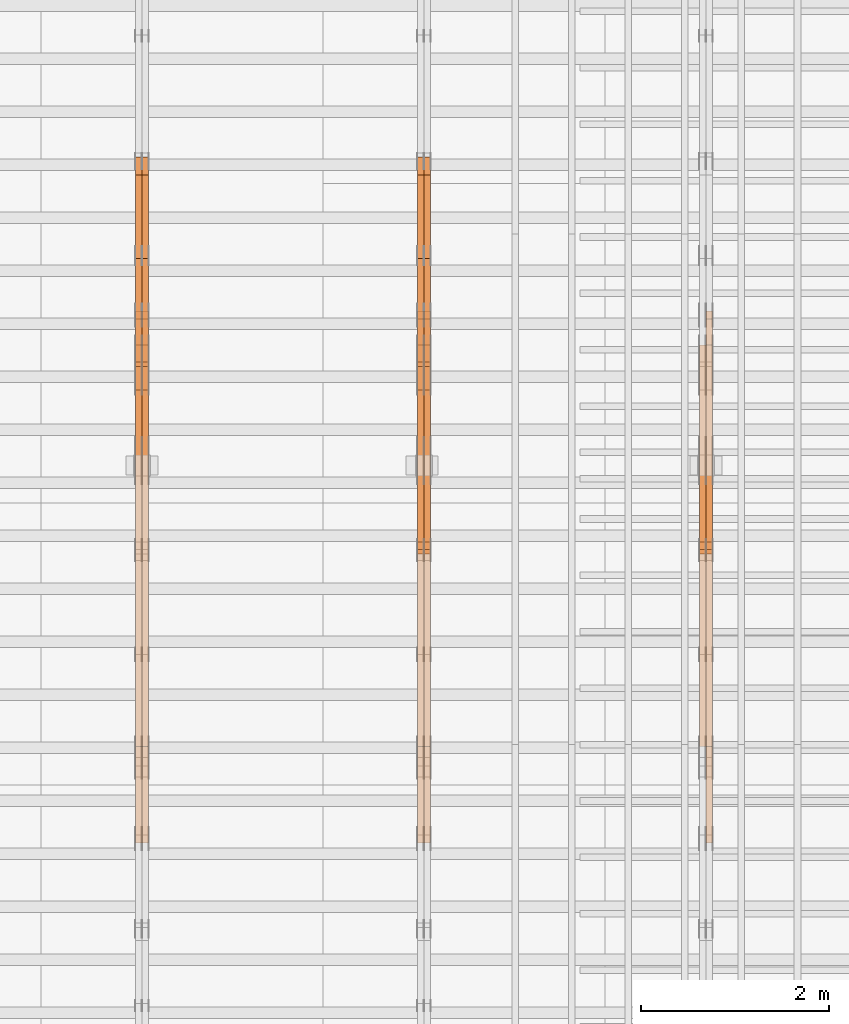
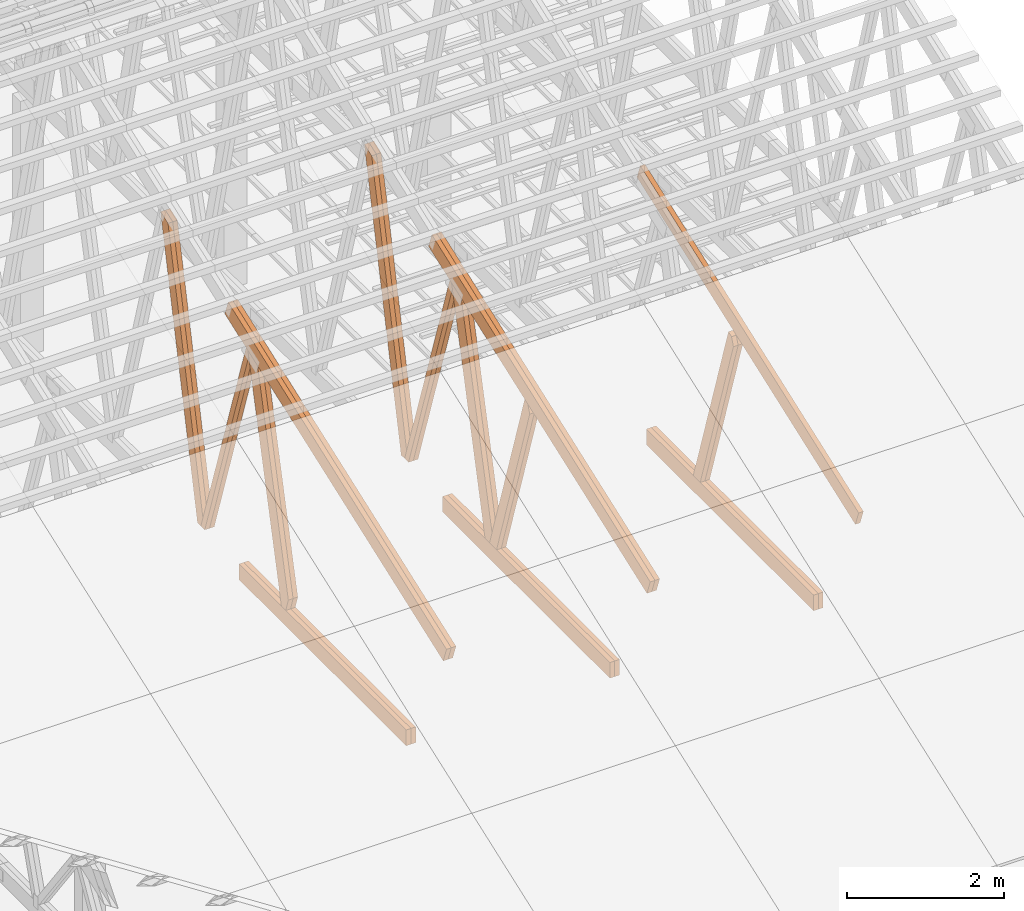
# One storey, part 51 of 189: 27 proxies.
"""IFC2X3 building model written with IfcOpenShell, lengths in millimetres."""

import ifcopenshell
import ifcopenshell.guid

model = None  # the IFC model being written
_history = None  # IfcOwnerHistory: only IFC2X3 demands one
_inside = {}  # id of a spatial element -> (the spatial element, [elements in it])
_under = {}  # id of a project, library or spatial element -> (it, [spatial elements below it])
_declared = {}  # id of a project -> (the project, [libraries it declares])
_typed = {}  # id of a type object -> (the type object, [elements of that type])
_made_of = {}  # id of a material, layer set ... -> (it, [elements and type objects made of it])


def new_model(schema):
    """Start an empty IFC model of exactly this schema.

    Asked for "IFC4X3", IfcOpenShell would pick the latest addendum, in which some entities
    have other attributes; the version numbers below select the first issue.
    IFC2X3 requires an IfcOwnerHistory on every rooted entity: one is made here for all.
    """
    global model, _history
    if schema == "IFC4X3":
        model = ifcopenshell.file(schema_version=(4, 3, 0, 0))
    else:
        model = ifcopenshell.file(schema=schema)
    _inside.clear()
    _under.clear()
    _declared.clear()
    _typed.clear()
    _made_of.clear()
    _history = None
    if model.schema == "IFC2X3":
        org = make("IfcOrganization", Name="unknown")
        user = make(
            "IfcPersonAndOrganization",
            ThePerson=make("IfcPerson", FamilyName="unknown"),
            TheOrganization=org,
        )
        app = make(
            "IfcApplication",
            ApplicationDeveloper=org,
            Version="unknown",
            ApplicationFullName="unknown",
            ApplicationIdentifier="unknown",
        )
        _history = make(
            "IfcOwnerHistory",
            OwningUser=user,
            OwningApplication=app,
            ChangeAction="ADDED",
            CreationDate=0,
        )
    return model


def make(cls, **values):
    """One entity of the class cls with the attributes given. An attribute that is None is left unset."""
    return model.create_entity(
        cls, **{name: value for name, value in values.items() if value is not None}
    )


def entity(cls, *values):
    """Any entity or typed value of the class cls, its attributes in the order of the schema. None: left unset."""
    e = model.create_entity(cls)
    for i, value in enumerate(values):
        if value is not None:
            e[i] = value
    return e


def rooted(cls, **values):
    """An entity with a GlobalId (a new one), such as an element, a storey or a relation."""
    return make(cls, GlobalId=ifcopenshell.guid.new(), OwnerHistory=_history, **values)


def si_unit(unit_type, name, prefix=None):
    """IfcSIUnit, for example si_unit("LENGTHUNIT", "METRE", prefix="MILLI")."""
    return make("IfcSIUnit", UnitType=unit_type, Prefix=prefix, Name=name)


def converted_unit(unit_type, name, factor, base, dimensions=None, offset=None):
    """IfcConversionBasedUnit, such as the inch: factor (a typed value) times the base unit."""
    return make(
        "IfcConversionBasedUnit"
        if offset is None
        else "IfcConversionBasedUnitWithOffset",
        ConversionOffset=offset,
        Dimensions=None
        if dimensions is None
        else entity("IfcDimensionalExponents", *dimensions),
        UnitType=unit_type,
        Name=name,
        ConversionFactor=make(
            "IfcMeasureWithUnit", ValueComponent=factor, UnitComponent=base
        ),
    )


def derived_unit(unit_type, elements):
    """IfcDerivedUnit: a product of units, each with its exponent."""
    return make(
        "IfcDerivedUnit",
        Elements=[
            make("IfcDerivedUnitElement", Unit=unit, Exponent=power)
            for unit, power in elements
        ],
        UnitType=unit_type,
    )


def assignment(units):
    """IfcUnitAssignment: the units of a project."""
    return None if units is None else make("IfcUnitAssignment", Units=units)


def point(xyz):
    """IfcCartesianPoint."""
    return None if xyz is None else make("IfcCartesianPoint", Coordinates=xyz)


def direction(xyz):
    """IfcDirection."""
    return None if xyz is None else make("IfcDirection", DirectionRatios=xyz)


def frame(location, z_axis=None, x_axis=None):
    """IfcAxis2Placement3D, a coordinate frame: its origin and axes. An axis left out is left unset."""
    return make(
        "IfcAxis2Placement3D",
        Location=point(location),
        Axis=direction(z_axis),
        RefDirection=direction(x_axis),
    )


def frame_2d(location, x_axis=None):
    """IfcAxis2Placement2D, a coordinate frame in the plane: its origin and x axis."""
    return make(
        "IfcAxis2Placement2D", Location=point(location), RefDirection=direction(x_axis)
    )


def origin():
    """The frame at (0, 0, 0) with its axes left unset."""
    return frame((0.0, 0.0, 0.0))


def origin_2d_with_axis():
    """The frame at (0, 0) in the plane with the x axis (1, 0) written out."""
    return frame_2d((0.0, 0.0), x_axis=(1.0, 0.0))


def place(relative_to, where):
    """IfcLocalPlacement: puts the frame where relative to a parent placement (None: the world)."""
    return make(
        "IfcLocalPlacement", PlacementRelTo=relative_to, RelativePlacement=where
    )


def context(
    kind, dimensions, precision=None, world=None, true_north=None, identifier=None
):
    """IfcGeometricRepresentationContext, for example the 3D "Model" context."""
    return make(
        "IfcGeometricRepresentationContext",
        ContextIdentifier=identifier,
        ContextType=kind,
        CoordinateSpaceDimension=dimensions,
        Precision=precision,
        WorldCoordinateSystem=world,
        TrueNorth=true_north,
    )


def subcontext(parent, identifier, kind, view, scale=None):
    """IfcGeometricRepresentationSubContext, for example "Body" below "Model"."""
    return make(
        "IfcGeometricRepresentationSubContext",
        ContextIdentifier=identifier,
        ContextType=kind,
        ParentContext=parent,
        TargetScale=scale,
        TargetView=view,
    )


def project(units=None, contexts=None):
    """IfcProject with its units and contexts."""
    return rooted(
        "IfcProject",
        Name="project",
        RepresentationContexts=contexts,
        UnitsInContext=assignment(units),
    )


def spatial(cls, under=None, at=None, **own):
    """A site, building, storey or space (cls), placed at a placement, below another one or the project."""
    s = rooted(cls, ObjectPlacement=at, **own)
    if under is not None:
        _under.setdefault(under.id(), (under, []))[1].append(s)
    return s


def polyline(points):
    """IfcPolyline through the points."""
    return make("IfcPolyline", Points=[point(p) for p in points])


def profile(cls, at=None, kind="AREA", **sizes):
    """A parametric profile (cls). Its sizes go by their IFC names, for example OverallWidth=200.0."""
    return make(cls, ProfileType=kind, Position=at, **sizes)


def rectangle(**sizes):
    """IfcRectangleProfileDef."""
    return profile("IfcRectangleProfileDef", **sizes)


def outline(outer, holes=None, kind="AREA"):
    """IfcArbitraryClosedProfileDef: a profile drawn as a closed curve; with holes, ...WithVoids."""
    if holes is None:
        return make("IfcArbitraryClosedProfileDef", ProfileType=kind, OuterCurve=outer)
    return make(
        "IfcArbitraryProfileDefWithVoids",
        ProfileType=kind,
        OuterCurve=outer,
        InnerCurves=holes,
    )


def extrude(swept, where, along, depth):
    """IfcExtrudedAreaSolid: the profile swept, set in the frame where, extruded along a direction by depth."""
    return make(
        "IfcExtrudedAreaSolid",
        SweptArea=swept,
        Position=where,
        ExtrudedDirection=direction(along),
        Depth=depth,
    )


def shape(context_of_items, identifier, shape_type, items):
    """IfcShapeRepresentation: the items that make up one representation, for example the "Body"."""
    return make(
        "IfcShapeRepresentation",
        ContextOfItems=context_of_items,
        RepresentationIdentifier=identifier,
        RepresentationType=shape_type,
        Items=items,
    )


def source(mapping_origin, context_of_items, identifier, shape_type, items):
    """IfcRepresentationMap: a shape defined once, which mapped items show again and again."""
    return make(
        "IfcRepresentationMap",
        MappingOrigin=mapping_origin,
        MappedRepresentation=shape(context_of_items, identifier, shape_type, items),
    )


def transform(
    local_origin,
    x_axis=None,
    y_axis=None,
    z_axis=None,
    scale=None,
    scale2=None,
    scale3=None,
    uniform=True,
):
    """IfcCartesianTransformationOperator3D, or its non-uniform kind. x_axis, y_axis, z_axis: its Axis1, 2, 3."""
    if uniform:
        return make(
            "IfcCartesianTransformationOperator3D",
            Axis1=direction(x_axis),
            Axis2=direction(y_axis),
            LocalOrigin=point(local_origin),
            Scale=scale,
            Axis3=direction(z_axis),
        )
    return make(
        "IfcCartesianTransformationOperator3DnonUniform",
        Axis1=direction(x_axis),
        Axis2=direction(y_axis),
        LocalOrigin=point(local_origin),
        Scale=scale,
        Axis3=direction(z_axis),
        Scale2=scale2,
        Scale3=scale3,
    )


def mapped(mapping_source, mapping_target):
    """IfcMappedItem: shows the shape of a source again, moved by a transform."""
    return make(
        "IfcMappedItem", MappingSource=mapping_source, MappingTarget=mapping_target
    )


def material(Name=None, Category=None):
    """IfcMaterial."""
    return make("IfcMaterial", Name=Name, Category=Category)


def made_of(thing, what):
    """Note that an element or type object is made of a material, layer set ...; save() writes the relation."""
    if what is not None:
        _made_of.setdefault(what.id(), (what, []))[1].append(thing)
    return thing


def type_object(cls, material=None, **own):
    """A type object (cls), such as IfcWallType, which elements share."""
    return made_of(rooted(cls, **own), material)


def type_shapes(of_type, sources):
    """Give a type object the sources (RepresentationMaps) that its elements show as mapped items."""
    of_type.RepresentationMaps = sources


def element(
    cls,
    number,
    at=None,
    inside=None,
    cuts=None,
    type_object=None,
    material=None,
    context=None,
    identifier="Body",
    shape_type=None,
    held_by="IfcProductDefinitionShape",
    body=None,
    shapes=None,
    **own,
):
    """One element of the class cls, such as IfcWall. Its Tag is "e" and its number.

    at: its placement. inside: the storey or other place that contains it. cuts: it is an
    opening in that element (IfcRelVoidsElement). A single representation is given by context,
    identifier, shape_type and body (its items); several are given by shapes. held_by: the class
    of the entity that holds the representations. save() writes the other relations.
    """
    e = rooted(cls, Tag="e%d" % number, ObjectPlacement=at, **own)
    if body is not None:
        shapes = [shape(context, identifier, shape_type, body)]
    if shapes is not None:
        e.Representation = make(held_by, Representations=shapes)
    if inside is not None:
        _inside.setdefault(inside.id(), (inside, []))[1].append(e)
    if cuts is not None:
        rooted(
            "IfcRelVoidsElement", RelatingBuildingElement=cuts, RelatedOpeningElement=e
        )
    if type_object is not None:
        _typed.setdefault(type_object.id(), (type_object, []))[1].append(e)
    return made_of(e, material)


def aggregate(whole, parts):
    """IfcRelAggregates: a whole, such as a stair, and the parts it consists of."""
    return rooted("IfcRelAggregates", RelatingObject=whole, RelatedObjects=parts)


def save(model, path):
    """Write the relations noted so far, then the file.

    IfcRelAggregates (storeys below a building ...), IfcRelContainedInSpatialStructure (elements
    in a storey), IfcRelDefinesByType, IfcRelAssociatesMaterial and IfcRelDeclares: one each for
    every whole, place, type object, material and project.
    """
    for whole, parts in _under.values():
        aggregate(whole, parts)
    for where, things in _inside.values():
        rooted(
            "IfcRelContainedInSpatialStructure",
            RelatedElements=things,
            RelatingStructure=where,
        )
    for kind, things in _typed.values():
        rooted("IfcRelDefinesByType", RelatedObjects=things, RelatingType=kind)
    for what, things in _made_of.values():
        rooted("IfcRelAssociatesMaterial", RelatedObjects=things, RelatingMaterial=what)
    for by, libraries in _declared.values():
        rooted("IfcRelDeclares", RelatingContext=by, RelatedDefinitions=libraries)
    model.write(path)


model = new_model("IFC2X3")

# Units and contexts
model_context = context("Model", 3, precision=0.01, world=origin(), true_north=direction((6.12303176911189e-17, 1.0)))
body_context = subcontext(model_context, "Body", "Model", "MODEL_VIEW")
ifc_project = project(units=[si_unit("LENGTHUNIT", "METRE", prefix="MILLI"), si_unit("AREAUNIT", "SQUARE_METRE"), si_unit("VOLUMEUNIT", "CUBIC_METRE"), converted_unit("PLANEANGLEUNIT", "DEGREE", entity("IfcRatioMeasure", 0.0174532925199433), si_unit("PLANEANGLEUNIT", "RADIAN"), dimensions=[0, 0, 0, 0, 0, 0, 0]), si_unit("MASSUNIT", "GRAM", prefix="KILO"), derived_unit("MASSDENSITYUNIT", [(si_unit("MASSUNIT", "GRAM", prefix="KILO"), 1), (si_unit("LENGTHUNIT", "METRE"), -3)]), si_unit("TIMEUNIT", "SECOND"), si_unit("FREQUENCYUNIT", "HERTZ"), si_unit("THERMODYNAMICTEMPERATUREUNIT", "DEGREE_CELSIUS"), derived_unit("THERMALTRANSMITTANCEUNIT", [(si_unit("MASSUNIT", "GRAM", prefix="KILO"), 1), (si_unit("THERMODYNAMICTEMPERATUREUNIT", "KELVIN"), -1), (si_unit("TIMEUNIT", "SECOND"), -3)]), derived_unit("VOLUMETRICFLOWRATEUNIT", [(si_unit("LENGTHUNIT", "METRE"), 3), (si_unit("TIMEUNIT", "SECOND"), -1)]), si_unit("ELECTRICCURRENTUNIT", "AMPERE"), si_unit("ELECTRICVOLTAGEUNIT", "VOLT"), si_unit("POWERUNIT", "WATT"), si_unit("FORCEUNIT", "NEWTON"), si_unit("ILLUMINANCEUNIT", "LUX"), si_unit("LUMINOUSFLUXUNIT", "LUMEN"), si_unit("LUMINOUSINTENSITYUNIT", "CANDELA"), derived_unit("USERDEFINED", [(si_unit("MASSUNIT", "GRAM", prefix="KILO"), -1), (si_unit("LENGTHUNIT", "METRE"), -2), (si_unit("TIMEUNIT", "SECOND"), 3), (si_unit("LUMINOUSFLUXUNIT", "LUMEN"), 1)]), derived_unit("LINEARVELOCITYUNIT", [(si_unit("LENGTHUNIT", "METRE"), 1), (si_unit("TIMEUNIT", "SECOND"), -1)]), si_unit("PRESSUREUNIT", "PASCAL"), derived_unit("USERDEFINED", [(si_unit("LENGTHUNIT", "METRE"), -2), (si_unit("MASSUNIT", "GRAM", prefix="KILO"), 1), (si_unit("TIMEUNIT", "SECOND"), -2)])], contexts=[model_context])

# Site, building, storey
site_placement = place(None, origin())
site = spatial("IfcSite", under=ifc_project, at=site_placement, CompositionType="ELEMENT")
building_placement = place(site_placement, origin())
building = spatial("IfcBuilding", under=site, at=building_placement, CompositionType="ELEMENT")
storey_placement = place(building_placement, origin())
storey = spatial("IfcBuildingStorey", under=building, at=storey_placement, Name="Default", CompositionType="ELEMENT", Elevation=0.0)

# Proxies
ifc_material_1 = material(Name="IfcSurfaceStyle #241004")
building_element_proxy_type_1 = type_object("IfcBuildingElementProxyType", Name="T1-W4 241002", PredefinedType="NOTDEFINED", material=ifc_material_1)
shared_shape_1 = source(origin(), body_context, "Body", "SweptSolid", [
    extrude(outline(polyline([(-1688.09292256655, -85.0003489723785), (1071.44998120742, -85.0003489723785), (1178.19407811536, -0.00016040063201781), (1181.35435681367, 85.0004291726946), (-1742.9054935699, 85.0004291726946), (-1688.09292256655, -85.0003489723785)])), frame((1181.35446122976, 85.0007670757732, 0.0), z_axis=(0.0, 0.0, 1.0), x_axis=(-1.0, 0.0, 0.0)), (0.0, 0.0, 1.0), 69.9999999999998),
])
type_shapes(building_element_proxy_type_1, [shared_shape_1])
proxy_1_placement = place(building_placement, frame((45300.0, 7937.17021143291, 3028.170124945), z_axis=(-1.0, 0.0, 0.0), x_axis=(0.0, 0.306868406216492, -0.951751953644514)))
element("IfcBuildingElementProxy", 1, at=proxy_1_placement, inside=storey, type_object=building_element_proxy_type_1, material=ifc_material_1, Name="T1-W4", context=body_context, shape_type="MappedRepresentation", body=[
    mapped(shared_shape_1, transform((0.0, 0.0, 0.0), scale=1.0)),
])
ifc_material_2 = material(Name="IfcSurfaceStyle #240938")
building_element_proxy_type_2 = type_object("IfcBuildingElementProxyType", Name="T1-W4 240936", PredefinedType="NOTDEFINED", material=ifc_material_2)
shared_shape_2 = source(origin(), body_context, "Body", "SweptSolid", [
    extrude(outline(polyline([(-1688.09292256655, -85.0003489723785), (1071.44998120742, -85.0003489723785), (1178.19407811536, -0.00016040063201781), (1181.35435681367, 85.0004291726946), (-1742.9054935699, 85.0004291726946), (-1688.09292256655, -85.0003489723785)])), frame((1181.35446122976, 85.0007670757732, 0.0), z_axis=(0.0, 0.0, 1.0), x_axis=(-1.0, 0.0, 0.0)), (0.0, 0.0, 1.0), 69.9999999999998),
])
type_shapes(building_element_proxy_type_2, [shared_shape_2])
proxy_2_placement = place(building_placement, frame((45230.0, 7937.17021143291, 3028.170124945), z_axis=(-1.0, 0.0, 0.0), x_axis=(0.0, 0.306868406216492, -0.951751953644514)))
element("IfcBuildingElementProxy", 2, at=proxy_2_placement, inside=storey, type_object=building_element_proxy_type_2, material=ifc_material_2, Name="T1-W4", context=body_context, shape_type="MappedRepresentation", body=[
    mapped(shared_shape_2, transform((0.0, 0.0, 0.0), scale=1.0)),
])
ifc_material_3 = material(Name="IfcSurfaceStyle #237926")
building_element_proxy_type_3 = type_object("IfcBuildingElementProxyType", Name="T1-B6 237924", PredefinedType="NOTDEFINED", material=ifc_material_3)
shared_shape_3 = source(origin(), body_context, "Body", "SweptSolid", [
    extrude(rectangle(XDim=4266.763671875, YDim=245.000000000001, at=origin_2d_with_axis()), frame((2133.3818359375, 122.500000000001, 0.0), z_axis=(0.0, 0.0, 1.0), x_axis=(-1.0, 0.0, 0.0)), (0.0, 0.0, 1.0), 69.9999999999997),
])
type_shapes(building_element_proxy_type_3, [shared_shape_3])
proxy_3_placement = place(building_placement, frame((45300.0, 5762.466796875, 245.0), z_axis=(-1.0, 0.0, 0.0), x_axis=(0.0, 1.0, 0.0)))
element("IfcBuildingElementProxy", 3, at=proxy_3_placement, inside=storey, type_object=building_element_proxy_type_3, material=ifc_material_3, Name="T1-B6", context=body_context, shape_type="MappedRepresentation", body=[
    mapped(shared_shape_3, transform((0.0, 0.0, 0.0), scale=1.0)),
])
ifc_material_4 = material(Name="IfcSurfaceStyle #237869")
building_element_proxy_type_4 = type_object("IfcBuildingElementProxyType", Name="T1-B6 237867", PredefinedType="NOTDEFINED", material=ifc_material_4)
shared_shape_4 = source(origin(), body_context, "Body", "SweptSolid", [
    extrude(rectangle(XDim=4266.763671875, YDim=245.000000000001, at=origin_2d_with_axis()), frame((2133.3818359375, 122.500000000001, 0.0), z_axis=(0.0, 0.0, 1.0), x_axis=(-1.0, 0.0, 0.0)), (0.0, 0.0, 1.0), 69.9999999999997),
])
type_shapes(building_element_proxy_type_4, [shared_shape_4])
proxy_4_placement = place(building_placement, frame((45230.0, 5762.466796875, 245.0), z_axis=(-1.0, 0.0, 0.0), x_axis=(0.0, 1.0, 0.0)))
element("IfcBuildingElementProxy", 4, at=proxy_4_placement, inside=storey, type_object=building_element_proxy_type_4, material=ifc_material_4, Name="T1-B6", context=body_context, shape_type="MappedRepresentation", body=[
    mapped(shared_shape_4, transform((0.0, 0.0, 0.0), scale=1.0)),
])
ifc_material_5 = material(Name="IfcSurfaceStyle #237566")
building_element_proxy_type_5 = type_object("IfcBuildingElementProxyType", Name="T1-T1 237564", PredefinedType="NOTDEFINED", material=ifc_material_5)
shared_shape_5 = source(origin(), body_context, "Body", "SweptSolid", [
    extrude(outline(polyline([(-2964.99981923522, -122.500027388895), (2964.99982426074, -122.500027388895), (2964.99984011048, 122.500027388895), (-2964.99984513599, 122.500027388895), (-2964.99981923522, -122.500027388895)])), frame((2965.00021857317, 122.500056320695, 0.0), z_axis=(0.0, 0.0, 1.0), x_axis=(-1.0, 0.0, 0.0)), (0.0, 0.0, 1.0), 69.9999999999996),
])
type_shapes(building_element_proxy_type_5, [shared_shape_5])
proxy_5_placement = place(building_placement, frame((45300.0, 10391.0374749089, 3921.30478975487), z_axis=(-1.0, 0.0, 0.0), x_axis=(0.0, -0.939692620785908, -0.342020143325669)))
element("IfcBuildingElementProxy", 5, at=proxy_5_placement, inside=storey, type_object=building_element_proxy_type_5, material=ifc_material_5, Name="T1-T1", context=body_context, shape_type="MappedRepresentation", body=[
    mapped(shared_shape_5, transform((0.0, 0.0, 0.0), scale=1.0)),
])
ifc_material_6 = material(Name="IfcSurfaceStyle #226006")
building_element_proxy_type_6 = type_object("IfcBuildingElementProxyType", Name="T1-W3 226004", PredefinedType="NOTDEFINED", material=ifc_material_6)
shared_shape_6 = source(origin(), body_context, "Body", "SweptSolid", [
    extrude(outline(polyline([(-2625.55080717397, -84.9998286237256), (1749.48871563991, -84.9998286237256), (1768.20584427244, 0.000602085469291858), (1625.445846867, 85.0000405971208), (-2517.58959960538, 84.9990145648612), (-2625.55080717397, -84.9998286237256)])), frame((1768.20584427244, 85.0000405971208, 0.0), z_axis=(0.0, 0.0, 1.0), x_axis=(-1.0, 0.0, 0.0)), (0.0, 0.0, 1.0), 69.9999999999997),
])
type_shapes(building_element_proxy_type_6, [shared_shape_6])
proxy_6_placement = place(building_placement, frame((42300.0, 10918.6728403286, 263.278932236374), z_axis=(-1.0, 0.0, 0.0), x_axis=(0.0, 0.215047682154604, 0.976603550269982)))
element("IfcBuildingElementProxy", 6, at=proxy_6_placement, inside=storey, type_object=building_element_proxy_type_6, material=ifc_material_6, Name="T1-W3", context=body_context, shape_type="MappedRepresentation", body=[
    mapped(shared_shape_6, transform((0.0, 0.0, 0.0), scale=1.0)),
])
ifc_material_7 = material(Name="IfcSurfaceStyle #225940")
building_element_proxy_type_7 = type_object("IfcBuildingElementProxyType", Name="T1-W3 225938", PredefinedType="NOTDEFINED", material=ifc_material_7)
shared_shape_7 = source(origin(), body_context, "Body", "SweptSolid", [
    extrude(outline(polyline([(-2625.55080717397, -84.9998286237256), (1749.48871563991, -84.9998286237256), (1768.20584427244, 0.000602085469291858), (1625.445846867, 85.0000405971208), (-2517.58959960538, 84.9990145648612), (-2625.55080717397, -84.9998286237256)])), frame((1768.20584427244, 85.0000405971208, 0.0), z_axis=(0.0, 0.0, 1.0), x_axis=(-1.0, 0.0, 0.0)), (0.0, 0.0, 1.0), 69.9999999999997),
])
type_shapes(building_element_proxy_type_7, [shared_shape_7])
proxy_7_placement = place(building_placement, frame((42230.0, 10918.6728403286, 263.278932236374), z_axis=(-1.0, 0.0, 0.0), x_axis=(0.0, 0.215047682154604, 0.976603550269982)))
element("IfcBuildingElementProxy", 7, at=proxy_7_placement, inside=storey, type_object=building_element_proxy_type_7, material=ifc_material_7, Name="T1-W3", context=body_context, shape_type="MappedRepresentation", body=[
    mapped(shared_shape_7, transform((0.0, 0.0, 0.0), scale=1.0)),
])
ifc_material_8 = material(Name="IfcSurfaceStyle #225742")
building_element_proxy_type_8 = type_object("IfcBuildingElementProxyType", Name="T1-W7 225740", PredefinedType="NOTDEFINED", material=ifc_material_8)
shared_shape_8 = source(origin(), body_context, "Body", "SweptSolid", [
    extrude(outline(polyline([(-2158.15323194511, -47.5001976605119), (1398.58481981178, -47.5001976605119), (1473.93376219819, -0.000131511554346808), (1475.30069254941, 47.5002634162891), (-2189.66604261427, 47.5002634162891), (-2158.15323194511, -47.5001976605119)])), frame((1475.30069254941, 47.5002634162891, 0.0), z_axis=(0.0, 0.0, 1.0), x_axis=(-1.0, 0.0, 0.0)), (0.0, 0.0, 1.0), 69.9999999999998),
])
type_shapes(building_element_proxy_type_8, [shared_shape_8])
proxy_8_placement = place(building_placement, frame((42300.0, 9847.787109375, 3723.57788085937), z_axis=(-1.0, 0.0, 0.0), x_axis=(0.0, 0.314845237923105, -0.949143021971475)))
element("IfcBuildingElementProxy", 8, at=proxy_8_placement, inside=storey, type_object=building_element_proxy_type_8, material=ifc_material_8, Name="T1-W7", context=body_context, shape_type="MappedRepresentation", body=[
    mapped(shared_shape_8, transform((0.0, 0.0, 0.0), scale=1.0)),
])
ifc_material_9 = material(Name="IfcSurfaceStyle #225676")
building_element_proxy_type_9 = type_object("IfcBuildingElementProxyType", Name="T1-W7 225674", PredefinedType="NOTDEFINED", material=ifc_material_9)
shared_shape_9 = source(origin(), body_context, "Body", "SweptSolid", [
    extrude(outline(polyline([(-2158.15323194511, -47.5001976605119), (1398.58481981178, -47.5001976605119), (1473.93376219819, -0.000131511554346808), (1475.30069254941, 47.5002634162891), (-2189.66604261427, 47.5002634162891), (-2158.15323194511, -47.5001976605119)])), frame((1475.30069254941, 47.5002634162891, 0.0), z_axis=(0.0, 0.0, 1.0), x_axis=(-1.0, 0.0, 0.0)), (0.0, 0.0, 1.0), 69.9999999999998),
])
type_shapes(building_element_proxy_type_9, [shared_shape_9])
proxy_9_placement = place(building_placement, frame((42230.0, 9847.787109375, 3723.57788085937), z_axis=(-1.0, 0.0, 0.0), x_axis=(0.0, 0.314845237923105, -0.949143021971475)))
element("IfcBuildingElementProxy", 9, at=proxy_9_placement, inside=storey, type_object=building_element_proxy_type_9, material=ifc_material_9, Name="T1-W7", context=body_context, shape_type="MappedRepresentation", body=[
    mapped(shared_shape_9, transform((0.0, 0.0, 0.0), scale=1.0)),
])
ifc_material_10 = material(Name="IfcSurfaceStyle #225478")
building_element_proxy_type_10 = type_object("IfcBuildingElementProxyType", Name="T1-W1 225476", PredefinedType="NOTDEFINED", material=ifc_material_10)
shared_shape_10 = source(origin(), body_context, "Body", "SweptSolid", [
    extrude(outline(polyline([(-2144.69382208629, -109.99948311278), (1421.70798092021, -109.99948311278), (1448.88116133745, -0.000392715405943322), (1271.09900468242, 109.999679470483), (-1996.99432485378, 109.999679470483), (-2144.69382208629, -109.99948311278)])), frame((1448.88130194731, 110.000176487146, 0.0), z_axis=(0.0, 0.0, 1.0), x_axis=(-1.0, 0.0, 0.0)), (0.0, 0.0, 1.0), 69.9999999999998),
])
type_shapes(building_element_proxy_type_10, [shared_shape_10])
proxy_10_placement = place(building_placement, frame((42300.0, 8727.74270166583, 271.380182391418), z_axis=(-1.0, 0.0, 0.0), x_axis=(0.0, 0.239819839925978, 0.970817410421691)))
element("IfcBuildingElementProxy", 10, at=proxy_10_placement, inside=storey, type_object=building_element_proxy_type_10, material=ifc_material_10, Name="T1-W1", context=body_context, shape_type="MappedRepresentation", body=[
    mapped(shared_shape_10, transform((0.0, 0.0, 0.0), scale=1.0)),
])
ifc_material_11 = material(Name="IfcSurfaceStyle #225412")
building_element_proxy_type_11 = type_object("IfcBuildingElementProxyType", Name="T1-W1 225410", PredefinedType="NOTDEFINED", material=ifc_material_11)
shared_shape_11 = source(origin(), body_context, "Body", "SweptSolid", [
    extrude(outline(polyline([(-2144.69382208629, -109.99948311278), (1421.70798092021, -109.99948311278), (1448.88116133745, -0.000392715405943322), (1271.09900468242, 109.999679470483), (-1996.99432485378, 109.999679470483), (-2144.69382208629, -109.99948311278)])), frame((1448.88130194731, 110.000176487146, 0.0), z_axis=(0.0, 0.0, 1.0), x_axis=(-1.0, 0.0, 0.0)), (0.0, 0.0, 1.0), 69.9999999999998),
])
type_shapes(building_element_proxy_type_11, [shared_shape_11])
proxy_11_placement = place(building_placement, frame((42230.0, 8727.74270166583, 271.380182391418), z_axis=(-1.0, 0.0, 0.0), x_axis=(0.0, 0.239819839925978, 0.970817410421691)))
element("IfcBuildingElementProxy", 11, at=proxy_11_placement, inside=storey, type_object=building_element_proxy_type_11, material=ifc_material_11, Name="T1-W1", context=body_context, shape_type="MappedRepresentation", body=[
    mapped(shared_shape_11, transform((0.0, 0.0, 0.0), scale=1.0)),
])
ifc_material_12 = material(Name="IfcSurfaceStyle #225214")
building_element_proxy_type_12 = type_object("IfcBuildingElementProxyType", Name="T1-W4 225212", PredefinedType="NOTDEFINED", material=ifc_material_12)
shared_shape_12 = source(origin(), body_context, "Body", "SweptSolid", [
    extrude(outline(polyline([(-1688.09292256655, -85.0003489723785), (1071.44998120742, -85.0003489723785), (1178.19407811536, -0.00016040063201781), (1181.35435681367, 85.0004291726946), (-1742.9054935699, 85.0004291726946), (-1688.09292256655, -85.0003489723785)])), frame((1181.35446122976, 85.0007670757732, 0.0), z_axis=(0.0, 0.0, 1.0), x_axis=(-1.0, 0.0, 0.0)), (0.0, 0.0, 1.0), 69.9999999999998),
])
type_shapes(building_element_proxy_type_12, [shared_shape_12])
proxy_12_placement = place(building_placement, frame((42300.0, 7937.17021143291, 3028.170124945), z_axis=(-1.0, 0.0, 0.0), x_axis=(0.0, 0.306868406216492, -0.951751953644514)))
element("IfcBuildingElementProxy", 12, at=proxy_12_placement, inside=storey, type_object=building_element_proxy_type_12, material=ifc_material_12, Name="T1-W4", context=body_context, shape_type="MappedRepresentation", body=[
    mapped(shared_shape_12, transform((0.0, 0.0, 0.0), scale=1.0)),
])
ifc_material_13 = material(Name="IfcSurfaceStyle #225148")
building_element_proxy_type_13 = type_object("IfcBuildingElementProxyType", Name="T1-W4 225146", PredefinedType="NOTDEFINED", material=ifc_material_13)
shared_shape_13 = source(origin(), body_context, "Body", "SweptSolid", [
    extrude(outline(polyline([(-1688.09292256655, -85.0003489723785), (1071.44998120742, -85.0003489723785), (1178.19407811536, -0.00016040063201781), (1181.35435681367, 85.0004291726946), (-1742.9054935699, 85.0004291726946), (-1688.09292256655, -85.0003489723785)])), frame((1181.35446122976, 85.0007670757732, 0.0), z_axis=(0.0, 0.0, 1.0), x_axis=(-1.0, 0.0, 0.0)), (0.0, 0.0, 1.0), 69.9999999999998),
])
type_shapes(building_element_proxy_type_13, [shared_shape_13])
proxy_13_placement = place(building_placement, frame((42230.0, 7937.17021143291, 3028.170124945), z_axis=(-1.0, 0.0, 0.0), x_axis=(0.0, 0.306868406216492, -0.951751953644514)))
element("IfcBuildingElementProxy", 13, at=proxy_13_placement, inside=storey, type_object=building_element_proxy_type_13, material=ifc_material_13, Name="T1-W4", context=body_context, shape_type="MappedRepresentation", body=[
    mapped(shared_shape_13, transform((0.0, 0.0, 0.0), scale=1.0)),
])
ifc_material_14 = material(Name="IfcSurfaceStyle #222136")
building_element_proxy_type_14 = type_object("IfcBuildingElementProxyType", Name="T1-B6 222134", PredefinedType="NOTDEFINED", material=ifc_material_14)
shared_shape_14 = source(origin(), body_context, "Body", "SweptSolid", [
    extrude(rectangle(XDim=4266.763671875, YDim=245.000000000001, at=origin_2d_with_axis()), frame((2133.3818359375, 122.500000000001, 0.0), z_axis=(0.0, 0.0, 1.0), x_axis=(-1.0, 0.0, 0.0)), (0.0, 0.0, 1.0), 69.9999999999997),
])
type_shapes(building_element_proxy_type_14, [shared_shape_14])
proxy_14_placement = place(building_placement, frame((42300.0, 5762.466796875, 245.0), z_axis=(-1.0, 0.0, 0.0), x_axis=(0.0, 1.0, 0.0)))
element("IfcBuildingElementProxy", 14, at=proxy_14_placement, inside=storey, type_object=building_element_proxy_type_14, material=ifc_material_14, Name="T1-B6", context=body_context, shape_type="MappedRepresentation", body=[
    mapped(shared_shape_14, transform((0.0, 0.0, 0.0), scale=1.0)),
])
ifc_material_15 = material(Name="IfcSurfaceStyle #222079")
building_element_proxy_type_15 = type_object("IfcBuildingElementProxyType", Name="T1-B6 222077", PredefinedType="NOTDEFINED", material=ifc_material_15)
shared_shape_15 = source(origin(), body_context, "Body", "SweptSolid", [
    extrude(rectangle(XDim=4266.763671875, YDim=245.000000000001, at=origin_2d_with_axis()), frame((2133.3818359375, 122.500000000001, 0.0), z_axis=(0.0, 0.0, 1.0), x_axis=(-1.0, 0.0, 0.0)), (0.0, 0.0, 1.0), 69.9999999999997),
])
type_shapes(building_element_proxy_type_15, [shared_shape_15])
proxy_15_placement = place(building_placement, frame((42230.0, 5762.466796875, 245.0), z_axis=(-1.0, 0.0, 0.0), x_axis=(0.0, 1.0, 0.0)))
element("IfcBuildingElementProxy", 15, at=proxy_15_placement, inside=storey, type_object=building_element_proxy_type_15, material=ifc_material_15, Name="T1-B6", context=body_context, shape_type="MappedRepresentation", body=[
    mapped(shared_shape_15, transform((0.0, 0.0, 0.0), scale=1.0)),
])
ifc_material_16 = material(Name="IfcSurfaceStyle #221776")
building_element_proxy_type_16 = type_object("IfcBuildingElementProxyType", Name="T1-T1 221774", PredefinedType="NOTDEFINED", material=ifc_material_16)
shared_shape_16 = source(origin(), body_context, "Body", "SweptSolid", [
    extrude(outline(polyline([(-2964.99981923522, -122.500027388895), (2964.99982426074, -122.500027388895), (2964.99984011048, 122.500027388895), (-2964.99984513599, 122.500027388895), (-2964.99981923522, -122.500027388895)])), frame((2965.00021857317, 122.500056320695, 0.0), z_axis=(0.0, 0.0, 1.0), x_axis=(-1.0, 0.0, 0.0)), (0.0, 0.0, 1.0), 69.9999999999996),
])
type_shapes(building_element_proxy_type_16, [shared_shape_16])
proxy_16_placement = place(building_placement, frame((42300.0, 10391.0374749089, 3921.30478975487), z_axis=(-1.0, 0.0, 0.0), x_axis=(0.0, -0.939692620785908, -0.342020143325669)))
element("IfcBuildingElementProxy", 16, at=proxy_16_placement, inside=storey, type_object=building_element_proxy_type_16, material=ifc_material_16, Name="T1-T1", context=body_context, shape_type="MappedRepresentation", body=[
    mapped(shared_shape_16, transform((0.0, 0.0, 0.0), scale=1.0)),
])
ifc_material_17 = material(Name="IfcSurfaceStyle #221719")
building_element_proxy_type_17 = type_object("IfcBuildingElementProxyType", Name="T1-T1 221717", PredefinedType="NOTDEFINED", material=ifc_material_17)
shared_shape_17 = source(origin(), body_context, "Body", "SweptSolid", [
    extrude(outline(polyline([(-2964.99981923522, -122.500027388895), (2964.99982426074, -122.500027388895), (2964.99984011048, 122.500027388895), (-2964.99984513599, 122.500027388895), (-2964.99981923522, -122.500027388895)])), frame((2965.00021857317, 122.500056320695, 0.0), z_axis=(0.0, 0.0, 1.0), x_axis=(-1.0, 0.0, 0.0)), (0.0, 0.0, 1.0), 69.9999999999996),
])
type_shapes(building_element_proxy_type_17, [shared_shape_17])
proxy_17_placement = place(building_placement, frame((42230.0, 10391.0374749089, 3921.30478975487), z_axis=(-1.0, 0.0, 0.0), x_axis=(0.0, -0.939692620785908, -0.342020143325669)))
element("IfcBuildingElementProxy", 17, at=proxy_17_placement, inside=storey, type_object=building_element_proxy_type_17, material=ifc_material_17, Name="T1-T1", context=body_context, shape_type="MappedRepresentation", body=[
    mapped(shared_shape_17, transform((0.0, 0.0, 0.0), scale=1.0)),
])
ifc_material_18 = material(Name="IfcSurfaceStyle #210216")
building_element_proxy_type_18 = type_object("IfcBuildingElementProxyType", Name="T1-W3 210214", PredefinedType="NOTDEFINED", material=ifc_material_18)
shared_shape_18 = source(origin(), body_context, "Body", "SweptSolid", [
    extrude(outline(polyline([(-2625.55080717397, -84.9998286237256), (1749.48871563991, -84.9998286237256), (1768.20584427244, 0.000602085469291858), (1625.445846867, 85.0000405971208), (-2517.58959960538, 84.9990145648612), (-2625.55080717397, -84.9998286237256)])), frame((1768.20584427244, 85.0000405971208, 0.0), z_axis=(0.0, 0.0, 1.0), x_axis=(-1.0, 0.0, 0.0)), (0.0, 0.0, 1.0), 69.9999999999997),
])
type_shapes(building_element_proxy_type_18, [shared_shape_18])
proxy_18_placement = place(building_placement, frame((39300.0, 10918.6728403286, 263.278932236374), z_axis=(-1.0, 0.0, 0.0), x_axis=(0.0, 0.215047682154604, 0.976603550269982)))
element("IfcBuildingElementProxy", 18, at=proxy_18_placement, inside=storey, type_object=building_element_proxy_type_18, material=ifc_material_18, Name="T1-W3", context=body_context, shape_type="MappedRepresentation", body=[
    mapped(shared_shape_18, transform((0.0, 0.0, 0.0), scale=1.0)),
])
ifc_material_19 = material(Name="IfcSurfaceStyle #210150")
building_element_proxy_type_19 = type_object("IfcBuildingElementProxyType", Name="T1-W3 210148", PredefinedType="NOTDEFINED", material=ifc_material_19)
shared_shape_19 = source(origin(), body_context, "Body", "SweptSolid", [
    extrude(outline(polyline([(-2625.55080717397, -84.9998286237256), (1749.48871563991, -84.9998286237256), (1768.20584427244, 0.000602085469291858), (1625.445846867, 85.0000405971208), (-2517.58959960538, 84.9990145648612), (-2625.55080717397, -84.9998286237256)])), frame((1768.20584427244, 85.0000405971208, 0.0), z_axis=(0.0, 0.0, 1.0), x_axis=(-1.0, 0.0, 0.0)), (0.0, 0.0, 1.0), 69.9999999999997),
])
type_shapes(building_element_proxy_type_19, [shared_shape_19])
proxy_19_placement = place(building_placement, frame((39230.0, 10918.6728403286, 263.278932236374), z_axis=(-1.0, 0.0, 0.0), x_axis=(0.0, 0.215047682154604, 0.976603550269982)))
element("IfcBuildingElementProxy", 19, at=proxy_19_placement, inside=storey, type_object=building_element_proxy_type_19, material=ifc_material_19, Name="T1-W3", context=body_context, shape_type="MappedRepresentation", body=[
    mapped(shared_shape_19, transform((0.0, 0.0, 0.0), scale=1.0)),
])
ifc_material_20 = material(Name="IfcSurfaceStyle #209952")
building_element_proxy_type_20 = type_object("IfcBuildingElementProxyType", Name="T1-W7 209950", PredefinedType="NOTDEFINED", material=ifc_material_20)
shared_shape_20 = source(origin(), body_context, "Body", "SweptSolid", [
    extrude(outline(polyline([(-2158.15323194511, -47.5001976605119), (1398.58481981178, -47.5001976605119), (1473.93376219819, -0.000131511554346808), (1475.30069254941, 47.5002634162891), (-2189.66604261427, 47.5002634162891), (-2158.15323194511, -47.5001976605119)])), frame((1475.30069254941, 47.5002634162891, 0.0), z_axis=(0.0, 0.0, 1.0), x_axis=(-1.0, 0.0, 0.0)), (0.0, 0.0, 1.0), 69.9999999999998),
])
type_shapes(building_element_proxy_type_20, [shared_shape_20])
proxy_20_placement = place(building_placement, frame((39300.0, 9847.787109375, 3723.57788085937), z_axis=(-1.0, 0.0, 0.0), x_axis=(0.0, 0.314845237923105, -0.949143021971475)))
element("IfcBuildingElementProxy", 20, at=proxy_20_placement, inside=storey, type_object=building_element_proxy_type_20, material=ifc_material_20, Name="T1-W7", context=body_context, shape_type="MappedRepresentation", body=[
    mapped(shared_shape_20, transform((0.0, 0.0, 0.0), scale=1.0)),
])
ifc_material_21 = material(Name="IfcSurfaceStyle #209886")
building_element_proxy_type_21 = type_object("IfcBuildingElementProxyType", Name="T1-W7 209884", PredefinedType="NOTDEFINED", material=ifc_material_21)
shared_shape_21 = source(origin(), body_context, "Body", "SweptSolid", [
    extrude(outline(polyline([(-2158.15323194511, -47.5001976605119), (1398.58481981178, -47.5001976605119), (1473.93376219819, -0.000131511554346808), (1475.30069254941, 47.5002634162891), (-2189.66604261427, 47.5002634162891), (-2158.15323194511, -47.5001976605119)])), frame((1475.30069254941, 47.5002634162891, 0.0), z_axis=(0.0, 0.0, 1.0), x_axis=(-1.0, 0.0, 0.0)), (0.0, 0.0, 1.0), 69.9999999999998),
])
type_shapes(building_element_proxy_type_21, [shared_shape_21])
proxy_21_placement = place(building_placement, frame((39230.0, 9847.787109375, 3723.57788085937), z_axis=(-1.0, 0.0, 0.0), x_axis=(0.0, 0.314845237923105, -0.949143021971475)))
element("IfcBuildingElementProxy", 21, at=proxy_21_placement, inside=storey, type_object=building_element_proxy_type_21, material=ifc_material_21, Name="T1-W7", context=body_context, shape_type="MappedRepresentation", body=[
    mapped(shared_shape_21, transform((0.0, 0.0, 0.0), scale=1.0)),
])
ifc_material_22 = material(Name="IfcSurfaceStyle #209688")
building_element_proxy_type_22 = type_object("IfcBuildingElementProxyType", Name="T1-W1 209686", PredefinedType="NOTDEFINED", material=ifc_material_22)
shared_shape_22 = source(origin(), body_context, "Body", "SweptSolid", [
    extrude(outline(polyline([(-2144.69382208629, -109.99948311278), (1421.70798092021, -109.99948311278), (1448.88116133745, -0.000392715405943322), (1271.09900468242, 109.999679470483), (-1996.99432485378, 109.999679470483), (-2144.69382208629, -109.99948311278)])), frame((1448.88130194731, 110.000176487146, 0.0), z_axis=(0.0, 0.0, 1.0), x_axis=(-1.0, 0.0, 0.0)), (0.0, 0.0, 1.0), 69.9999999999998),
])
type_shapes(building_element_proxy_type_22, [shared_shape_22])
proxy_22_placement = place(building_placement, frame((39300.0, 8727.74270166583, 271.380182391418), z_axis=(-1.0, 0.0, 0.0), x_axis=(0.0, 0.239819839925978, 0.970817410421691)))
element("IfcBuildingElementProxy", 22, at=proxy_22_placement, inside=storey, type_object=building_element_proxy_type_22, material=ifc_material_22, Name="T1-W1", context=body_context, shape_type="MappedRepresentation", body=[
    mapped(shared_shape_22, transform((0.0, 0.0, 0.0), scale=1.0)),
])
ifc_material_23 = material(Name="IfcSurfaceStyle #209622")
building_element_proxy_type_23 = type_object("IfcBuildingElementProxyType", Name="T1-W1 209620", PredefinedType="NOTDEFINED", material=ifc_material_23)
shared_shape_23 = source(origin(), body_context, "Body", "SweptSolid", [
    extrude(outline(polyline([(-2144.69382208629, -109.99948311278), (1421.70798092021, -109.99948311278), (1448.88116133745, -0.000392715405943322), (1271.09900468242, 109.999679470483), (-1996.99432485378, 109.999679470483), (-2144.69382208629, -109.99948311278)])), frame((1448.88130194731, 110.000176487146, 0.0), z_axis=(0.0, 0.0, 1.0), x_axis=(-1.0, 0.0, 0.0)), (0.0, 0.0, 1.0), 69.9999999999998),
])
type_shapes(building_element_proxy_type_23, [shared_shape_23])
proxy_23_placement = place(building_placement, frame((39230.0, 8727.74270166583, 271.380182391418), z_axis=(-1.0, 0.0, 0.0), x_axis=(0.0, 0.239819839925978, 0.970817410421691)))
element("IfcBuildingElementProxy", 23, at=proxy_23_placement, inside=storey, type_object=building_element_proxy_type_23, material=ifc_material_23, Name="T1-W1", context=body_context, shape_type="MappedRepresentation", body=[
    mapped(shared_shape_23, transform((0.0, 0.0, 0.0), scale=1.0)),
])
ifc_material_24 = material(Name="IfcSurfaceStyle #206346")
building_element_proxy_type_24 = type_object("IfcBuildingElementProxyType", Name="T1-B6 206344", PredefinedType="NOTDEFINED", material=ifc_material_24)
shared_shape_24 = source(origin(), body_context, "Body", "SweptSolid", [
    extrude(rectangle(XDim=4266.763671875, YDim=245.000000000001, at=origin_2d_with_axis()), frame((2133.3818359375, 122.500000000001, 0.0), z_axis=(0.0, 0.0, 1.0), x_axis=(-1.0, 0.0, 0.0)), (0.0, 0.0, 1.0), 69.9999999999997),
])
type_shapes(building_element_proxy_type_24, [shared_shape_24])
proxy_24_placement = place(building_placement, frame((39300.0, 5762.466796875, 245.0), z_axis=(-1.0, 0.0, 0.0), x_axis=(0.0, 1.0, 0.0)))
element("IfcBuildingElementProxy", 24, at=proxy_24_placement, inside=storey, type_object=building_element_proxy_type_24, material=ifc_material_24, Name="T1-B6", context=body_context, shape_type="MappedRepresentation", body=[
    mapped(shared_shape_24, transform((0.0, 0.0, 0.0), scale=1.0)),
])
ifc_material_25 = material(Name="IfcSurfaceStyle #206289")
building_element_proxy_type_25 = type_object("IfcBuildingElementProxyType", Name="T1-B6 206287", PredefinedType="NOTDEFINED", material=ifc_material_25)
shared_shape_25 = source(origin(), body_context, "Body", "SweptSolid", [
    extrude(rectangle(XDim=4266.763671875, YDim=245.000000000001, at=origin_2d_with_axis()), frame((2133.3818359375, 122.500000000001, 0.0), z_axis=(0.0, 0.0, 1.0), x_axis=(-1.0, 0.0, 0.0)), (0.0, 0.0, 1.0), 69.9999999999997),
])
type_shapes(building_element_proxy_type_25, [shared_shape_25])
proxy_25_placement = place(building_placement, frame((39230.0, 5762.466796875, 245.0), z_axis=(-1.0, 0.0, 0.0), x_axis=(0.0, 1.0, 0.0)))
element("IfcBuildingElementProxy", 25, at=proxy_25_placement, inside=storey, type_object=building_element_proxy_type_25, material=ifc_material_25, Name="T1-B6", context=body_context, shape_type="MappedRepresentation", body=[
    mapped(shared_shape_25, transform((0.0, 0.0, 0.0), scale=1.0)),
])
ifc_material_26 = material(Name="IfcSurfaceStyle #205986")
building_element_proxy_type_26 = type_object("IfcBuildingElementProxyType", Name="T1-T1 205984", PredefinedType="NOTDEFINED", material=ifc_material_26)
shared_shape_26 = source(origin(), body_context, "Body", "SweptSolid", [
    extrude(outline(polyline([(-2964.99981923522, -122.500027388895), (2964.99982426074, -122.500027388895), (2964.99984011048, 122.500027388895), (-2964.99984513599, 122.500027388895), (-2964.99981923522, -122.500027388895)])), frame((2965.00021857317, 122.500056320695, 0.0), z_axis=(0.0, 0.0, 1.0), x_axis=(-1.0, 0.0, 0.0)), (0.0, 0.0, 1.0), 69.9999999999996),
])
type_shapes(building_element_proxy_type_26, [shared_shape_26])
proxy_26_placement = place(building_placement, frame((39300.0, 10391.0374749089, 3921.30478975487), z_axis=(-1.0, 0.0, 0.0), x_axis=(0.0, -0.939692620785908, -0.342020143325669)))
element("IfcBuildingElementProxy", 26, at=proxy_26_placement, inside=storey, type_object=building_element_proxy_type_26, material=ifc_material_26, Name="T1-T1", context=body_context, shape_type="MappedRepresentation", body=[
    mapped(shared_shape_26, transform((0.0, 0.0, 0.0), scale=1.0)),
])
ifc_material_27 = material(Name="IfcSurfaceStyle #205929")
building_element_proxy_type_27 = type_object("IfcBuildingElementProxyType", Name="T1-T1 205927", PredefinedType="NOTDEFINED", material=ifc_material_27)
shared_shape_27 = source(origin(), body_context, "Body", "SweptSolid", [
    extrude(outline(polyline([(-2964.99981923522, -122.500027388895), (2964.99982426074, -122.500027388895), (2964.99984011048, 122.500027388895), (-2964.99984513599, 122.500027388895), (-2964.99981923522, -122.500027388895)])), frame((2965.00021857317, 122.500056320695, 0.0), z_axis=(0.0, 0.0, 1.0), x_axis=(-1.0, 0.0, 0.0)), (0.0, 0.0, 1.0), 69.9999999999996),
])
type_shapes(building_element_proxy_type_27, [shared_shape_27])
proxy_27_placement = place(building_placement, frame((39230.0, 10391.0374749089, 3921.30478975487), z_axis=(-1.0, 0.0, 0.0), x_axis=(0.0, -0.939692620785908, -0.342020143325669)))
element("IfcBuildingElementProxy", 27, at=proxy_27_placement, inside=storey, type_object=building_element_proxy_type_27, material=ifc_material_27, Name="T1-T1", context=body_context, shape_type="MappedRepresentation", body=[
    mapped(shared_shape_27, transform((0.0, 0.0, 0.0), scale=1.0)),
])

save(model, "model.ifc")
